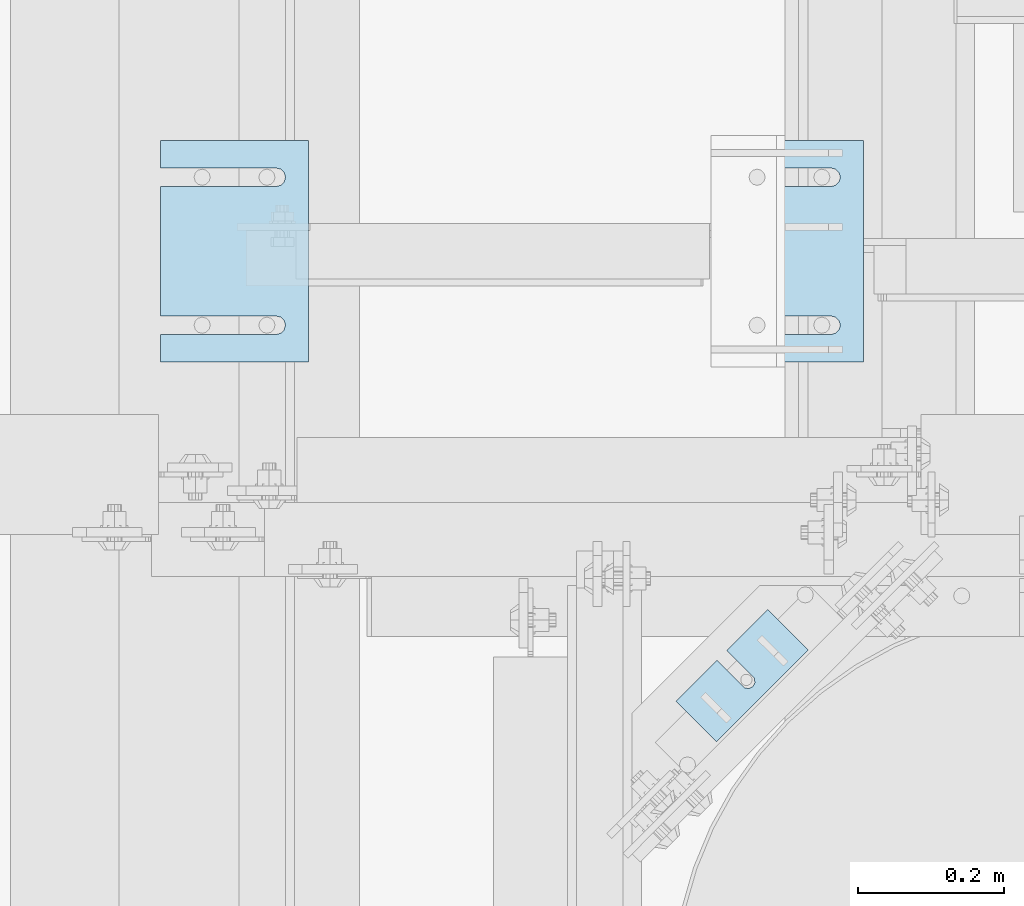
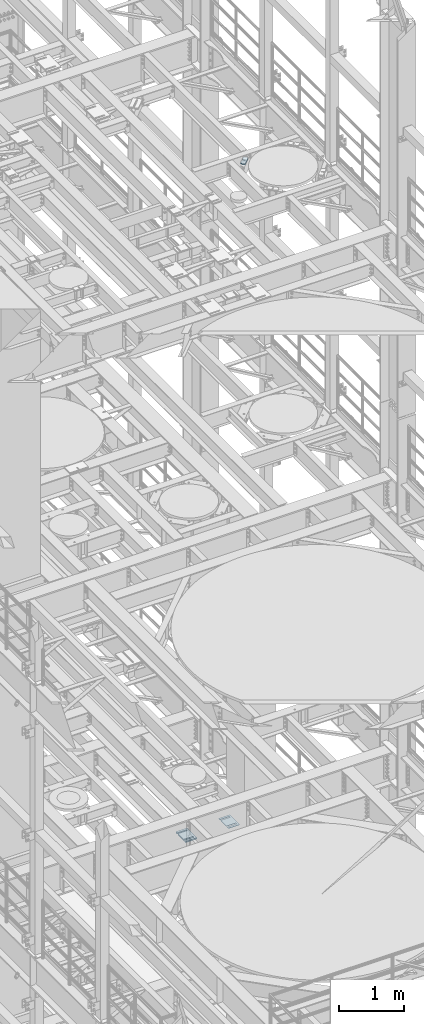
# One storey, part 1658 of 1876: 8 plates, 8 elements without a shape of their own.
"""IFC2X3 building model written with IfcOpenShell, lengths in millimetres."""

from ifc_helpers import new_model, si_unit, frame, origin_with_axes, place, context, subcontext, project, spatial, faceted_brep, material, type_object, element, aggregate, save


model = new_model("IFC2X3")

# Units and contexts
model_context = context("Model", 3, precision=1e-05, world=origin_with_axes())
body_context = subcontext(model_context, "Body", "Model", "MODEL_VIEW")
ifc_project = project(units=[si_unit("LENGTHUNIT", "METRE", prefix="MILLI"), si_unit("AREAUNIT", "SQUARE_METRE"), si_unit("VOLUMEUNIT", "CUBIC_METRE"), si_unit("MASSUNIT", "GRAM", prefix="KILO"), si_unit("TIMEUNIT", "SECOND"), si_unit("PLANEANGLEUNIT", "RADIAN"), si_unit("SOLIDANGLEUNIT", "STERADIAN"), si_unit("THERMODYNAMICTEMPERATUREUNIT", "DEGREE_CELSIUS"), si_unit("LUMINOUSINTENSITYUNIT", "LUMEN")], contexts=[model_context])

# Site, building, storey
site_placement = place(None, origin_with_axes())
site = spatial("IfcSite", under=ifc_project, at=site_placement, CompositionType="ELEMENT")
building_placement = place(site_placement, origin_with_axes())
building = spatial("IfcBuilding", under=site, at=building_placement, Name="Undefined", CompositionType="ELEMENT")
storey_placement = place(building_placement, origin_with_axes())
storey = spatial("IfcBuildingStorey", under=building, at=storey_placement, Name="Undefined", CompositionType="ELEMENT", Elevation=0.0)

# Assembly, plate
assembly_1_placement = place(storey_placement, origin_with_axes())
assembly_1 = element("IfcElementAssembly", 1, at=assembly_1_placement, inside=storey, Name="SHIM PLATE", AssemblyPlace="NOTDEFINED", PredefinedType="RIGID_FRAME")
ifc_material = material(Name="STEEL/A36")
plate_type_1 = type_object("IfcPlateType", PredefinedType="NOTDEFINED")
plate_1_placement = place(assembly_1_placement, frame((6334.01600597448, 4165.55524499807, 17987.9625), z_axis=(0.707106066686187, -0.707107495686186, 0.0), x_axis=(0.707107495686187, 0.707106066686186, 0.0)))
plate_1 = element("IfcPlate", 2, at=plate_1_placement, type_object=plate_type_1, material=ifc_material, Name="SHIM PLATE", context=body_context, shape_type="Brep", body=[
    faceted_brep([(79.3755953647978, -4.76250000000073, -2.27373675443232e-12), (79.3755953647978, 4.76250000000073, -2.27373675443232e-12), (79.3049756952787, 4.76250000000073, 47.6675290359171), (79.3049756952787, -4.76250000000073, 47.6675290359171), (79.4487723981238, 4.76250000000073, 53.7022829617517), (79.4487723981238, -4.76250000000073, 53.7022829617517), (83.0634981204839, 4.76250000000073, 58.5368140030459), (83.0634981204839, -4.76250000000073, 58.5368140030459), (88.8111609071975, 4.76250000000073, 60.3816188510955), (88.8111609071975, -4.76250000000073, 60.3816188510955), (94.5642614235203, 4.76250000000073, 58.5538423641483), (94.5642614235203, -4.76250000000073, 58.5538423641483), (98.354954051083, -4.76250000000073, 47.6957349820682), (98.354954051083, 4.76250000000073, 47.6957349820682), (98.4255737206076, 4.76250000000073, -2.27373675443232e-12), (98.4255737206076, -4.76250000000073, -2.27373675443232e-12), (98.1932875572456, -4.76250000000073, 53.7300366303025), (98.1932875572456, 4.76250000000073, 53.7300366303025), (0.0, -4.76249999999982, 0.0), (7.93202807471971e-05, -4.76250000000073, 78.4900512695085), (7.93202807471971e-05, 4.76250000000073, 78.4900512695085), (0.0, 4.76249999999982, 0.0), (177.801101684615, -4.76250000000073, 78.4900512695531), (177.801101684615, 4.76250000000073, 78.4900512695531), (177.801147461001, -4.76250000000073, -5.00222085975111e-12), (177.801147461001, 4.76250000000073, -5.00222085975111e-12)], [[[0, 1, 2, 3]], [[3, 2, 4, 5]], [[5, 4, 6, 7]], [[7, 6, 8, 9]], [[9, 8, 10, 11]], [[12, 13, 14, 15]], [[16, 17, 13, 12]], [[11, 10, 17, 16]], [[18, 19, 20, 21]], [[19, 22, 23, 20]], [[22, 24, 25, 23]], [[25, 24, 15, 14]], [[8, 6, 4, 2, 1, 21, 20, 23, 25, 14, 13, 17, 10]], [[18, 21, 1, 0]], [[15, 24, 22, 19, 18, 0, 3, 5, 7, 9, 11, 16, 12]]]),
])
aggregate(assembly_1, [plate_1])

assembly_2_placement = place(storey_placement, origin_with_axes())
assembly_2 = element("IfcElementAssembly", 3, at=assembly_2_placement, inside=storey, Name="SHIM PLATE", AssemblyPlace="NOTDEFINED", PredefinedType="RIGID_FRAME")
plate_type_2 = type_object("IfcPlateType", PredefinedType="NOTDEFINED")
plate_2_placement = place(assembly_2_placement, frame((5829.30163886406, 4935.78240966797, 5156.9925), z_axis=(0.0, -1.0, 0.0), x_axis=(-1.0, 0.0, 0.0)))
plate_2 = element("IfcPlate", 4, at=plate_2_placement, type_object=plate_type_2, material=ifc_material, Name="SHIM PLATE", context=body_context, shape_type="Brep", body=[
    faceted_brep([(203.203060149864, -0.793499999999767, 38.103375484061), (203.203060149864, 0.793499999999767, 38.103375484061), (44.4515180349072, 0.793499999999767, 38.1033599194234), (44.4515180349072, -0.793499999999767, 38.1033599194234), (38.1012989900946, 0.793499999999767, 39.8049650059329), (38.1012989900946, -0.793499999999767, 39.8049650059329), (33.4527432566938, 0.793499999999767, 44.4538004924834), (33.4527432566938, -0.793499999999767, 44.4538004924834), (31.7515203221337, 0.793499999999767, 50.8041219264314), (31.7515203221337, -0.793499999999767, 50.8041219264314), (33.4535054350818, 0.793499999999767, 57.1542391271487), (33.4535054350818, -0.793499999999767, 57.1542391271487), (38.1026191065821, 0.793499999999767, 61.8025166422076), (38.1026191065821, -0.793499999999767, 61.8025166422076), (44.4530423390133, 0.793499999999767, 63.5033595381083), (44.4530423390133, -0.793499999999767, 63.5033595381083), (203.203057597802, -0.793499999999767, 63.5033693805453), (203.203057606771, 0.793499999999767, 63.5033693805453), (203.203063964842, -0.793499999999767, -8.45830072648823e-11), (9.09494701772928e-13, -0.793499999999767, 0.0), (9.09494701772928e-13, 0.793499999999767, 0.0), (203.203063964842, 0.793499999999767, -8.45830072648823e-11), (-1.83106603799388e-05, -0.793499999999767, 304.8037109375), (-1.83106603799388e-05, 0.793499999999767, 304.8037109375), (203.203033447349, -0.793499999999767, 304.803710937444), (203.203033447349, 0.793499999999767, 304.803710937444), (203.20303725321, -0.793499999999767, 266.701819087575), (203.203037262178, 0.793499999999767, 266.701819087575), (44.4530372532099, -0.793499999999767, 266.701809245139), (44.4530372532099, 0.793499999999767, 266.701809245139), (38.1026140207787, -0.793499999999767, 265.000966349239), (38.1026140207787, 0.793499999999767, 265.000966349239), (33.4535003492774, -0.793499999999767, 260.352688834179), (33.4535003492774, 0.793499999999767, 260.352688834179), (31.7515152363312, -0.793499999999767, 254.002571633462), (31.7515152363312, 0.793499999999767, 254.002571633462), (33.4527381708904, -0.793499999999767, 247.652250199514), (33.4527381708904, 0.793499999999767, 247.652250199514), (38.1012939042912, -0.793499999999767, 243.003414712964), (38.1012939042912, 0.793499999999767, 243.003414712964), (44.4515129491037, -0.793499999999767, 241.301809626454), (44.4515129491037, 0.793499999999767, 241.301809626454), (203.203039805271, -0.793499999999767, 241.301825191091), (203.203039805271, 0.793499999999767, 241.301825191091)], [[[0, 1, 2, 3]], [[3, 2, 4, 5]], [[5, 4, 6, 7]], [[7, 6, 8, 9]], [[9, 8, 10, 11]], [[11, 10, 12, 13]], [[13, 12, 14, 15]], [[16, 15, 14, 17]], [[18, 19, 20, 21]], [[19, 22, 23, 20]], [[22, 24, 25, 23]], [[25, 24, 26, 27]], [[26, 28, 29, 27]], [[30, 31, 29, 28]], [[32, 33, 31, 30]], [[34, 35, 33, 32]], [[36, 37, 35, 34]], [[38, 39, 37, 36]], [[40, 41, 39, 38]], [[42, 43, 41, 40]], [[43, 42, 16, 17]], [[12, 10, 8, 6, 4, 2, 1, 21, 20, 23, 25, 27, 29, 31, 33, 35, 37, 39, 41, 43, 17, 14]], [[18, 21, 1, 0]], [[42, 40, 38, 36, 34, 32, 30, 28, 26, 24, 22, 19, 18, 0, 3, 5, 7, 9, 11, 13, 15, 16]]]),
])
aggregate(assembly_2, [plate_2])

assembly_3_placement = place(storey_placement, origin_with_axes())
assembly_3 = element("IfcElementAssembly", 5, at=assembly_3_placement, inside=storey, Name="SHIM PLATE", AssemblyPlace="NOTDEFINED", PredefinedType="RIGID_FRAME")
plate_type_3 = type_object("IfcPlateType", PredefinedType="NOTDEFINED")
plate_3_placement = place(assembly_3_placement, frame((5829.30163886406, 4935.78240966797, 5154.6115), z_axis=(0.0, -1.0, 0.0), x_axis=(-1.0, 0.0, 0.0)))
plate_3 = element("IfcPlate", 6, at=plate_3_placement, type_object=plate_type_3, material=ifc_material, Name="SHIM PLATE", context=body_context, shape_type="Brep", body=[
    faceted_brep([(203.203060149865, -1.58749999999964, 38.1033754840619), (203.203060149865, 1.58749999999964, 38.1033754840619), (44.4515180349081, 1.58749999999964, 38.1033599194243), (44.4515180349081, -1.58749999999964, 38.1033599194243), (38.1012989900955, 1.58749999999964, 39.8049650059338), (38.1012989900955, -1.58749999999964, 39.8049650059338), (33.4527432566947, 1.58749999999964, 44.4538004924843), (33.4527432566947, -1.58749999999964, 44.4538004924843), (31.7515203221346, 1.58749999999964, 50.8041219264323), (31.7515203221346, -1.58749999999964, 50.8041219264323), (33.4535054350827, 1.58749999999964, 57.1542391271496), (33.4535054350827, -1.58749999999964, 57.1542391271496), (38.102619106583, 1.58749999999964, 61.8025166422085), (38.102619106583, -1.58749999999964, 61.8025166422085), (44.4530423390142, 1.58749999999964, 63.5033595381092), (44.4530423390142, -1.58749999999964, 63.5033595381092), (203.203057597803, -1.58749999999964, 63.5033693805462), (203.203057606772, 1.58749999999964, 63.5033693805462), (203.203063964843, -1.58749999999964, -8.36735125631094e-11), (9.09494701772928e-13, -1.58750000000146, 4.54747350886464e-13), (9.09494701772928e-13, 1.58750000000146, 4.54747350886464e-13), (203.203063964843, 1.58749999999964, -8.36735125631094e-11), (-1.83106631084229e-05, -1.58749999999964, 304.803710937501), (-1.83106631084229e-05, 1.58749999999964, 304.803710937501), (203.20303344735, -1.58749999999964, 304.803710937445), (203.20303344735, 1.58749999999964, 304.803710937445), (203.203037253211, -1.58749999999964, 266.701819087576), (203.203037262179, 1.58749999999964, 266.701819087576), (44.4530372532108, -1.58749999999964, 266.70180924514), (44.4530372532108, 1.58749999999964, 266.70180924514), (38.1026140207796, -1.58749999999964, 265.00096634924), (38.1026140207796, 1.58749999999964, 265.00096634924), (33.4535003492783, -1.58749999999964, 260.35268883418), (33.4535003492783, 1.58749999999964, 260.35268883418), (31.7515152363321, -1.58749999999964, 254.002571633463), (31.7515152363321, 1.58749999999964, 254.002571633463), (33.4527381708913, -1.58749999999964, 247.652250199515), (33.4527381708913, 1.58749999999964, 247.652250199515), (38.1012939042921, -1.58749999999964, 243.003414712965), (38.1012939042921, 1.58749999999964, 243.003414712965), (44.4515129491047, -1.58749999999964, 241.301809626455), (44.4515129491047, 1.58749999999964, 241.301809626455), (203.203039805272, -1.58749999999964, 241.301825191092), (203.203039805272, 1.58749999999964, 241.301825191092)], [[[0, 1, 2, 3]], [[3, 2, 4, 5]], [[5, 4, 6, 7]], [[7, 6, 8, 9]], [[9, 8, 10, 11]], [[11, 10, 12, 13]], [[13, 12, 14, 15]], [[16, 15, 14, 17]], [[18, 19, 20, 21]], [[19, 22, 23, 20]], [[22, 24, 25, 23]], [[25, 24, 26, 27]], [[26, 28, 29, 27]], [[30, 31, 29, 28]], [[32, 33, 31, 30]], [[34, 35, 33, 32]], [[36, 37, 35, 34]], [[38, 39, 37, 36]], [[40, 41, 39, 38]], [[42, 43, 41, 40]], [[43, 42, 16, 17]], [[12, 10, 8, 6, 4, 2, 1, 21, 20, 23, 25, 27, 29, 31, 33, 35, 37, 39, 41, 43, 17, 14]], [[18, 21, 1, 0]], [[42, 40, 38, 36, 34, 32, 30, 28, 26, 24, 22, 19, 18, 0, 3, 5, 7, 9, 11, 13, 15, 16]]]),
])
aggregate(assembly_3, [plate_3])

assembly_4_placement = place(storey_placement, origin_with_axes())
assembly_4 = element("IfcElementAssembly", 7, at=assembly_4_placement, inside=storey, Name="SHIM PLATE", AssemblyPlace="NOTDEFINED", PredefinedType="RIGID_FRAME")
plate_4_placement = place(assembly_4_placement, frame((5829.30163886406, 4935.78240966797, 5151.4365), z_axis=(0.0, -1.0, 0.0), x_axis=(-1.0, 0.0, 0.0)))
plate_4 = element("IfcPlate", 8, at=plate_4_placement, type_object=plate_type_3, material=ifc_material, Name="SHIM PLATE", context=body_context, shape_type="Brep", body=[
    faceted_brep([(203.203060149865, -1.58749999999964, 38.1033754840619), (203.203060149865, 1.58749999999964, 38.1033754840619), (44.4515180349081, 1.58749999999964, 38.1033599194243), (44.4515180349081, -1.58749999999964, 38.1033599194243), (38.1012989900955, 1.58749999999964, 39.8049650059338), (38.1012989900955, -1.58749999999964, 39.8049650059338), (33.4527432566947, 1.58749999999964, 44.4538004924843), (33.4527432566947, -1.58749999999964, 44.4538004924843), (31.7515203221346, 1.58749999999964, 50.8041219264323), (31.7515203221346, -1.58749999999964, 50.8041219264323), (33.4535054350827, 1.58749999999964, 57.1542391271496), (33.4535054350827, -1.58749999999964, 57.1542391271496), (38.102619106583, 1.58749999999964, 61.8025166422085), (38.102619106583, -1.58749999999964, 61.8025166422085), (44.4530423390142, 1.58749999999964, 63.5033595381092), (44.4530423390142, -1.58749999999964, 63.5033595381092), (203.203057597803, -1.58749999999964, 63.5033693805462), (203.203057606772, 1.58749999999964, 63.5033693805462), (203.203063964843, -1.58749999999964, -8.36735125631094e-11), (9.09494701772928e-13, -1.58750000000146, 4.54747350886464e-13), (9.09494701772928e-13, 1.58750000000146, 4.54747350886464e-13), (203.203063964843, 1.58749999999964, -8.36735125631094e-11), (-1.83106631084229e-05, -1.58749999999964, 304.803710937501), (-1.83106631084229e-05, 1.58749999999964, 304.803710937501), (203.20303344735, -1.58749999999964, 304.803710937445), (203.20303344735, 1.58749999999964, 304.803710937445), (203.203037253211, -1.58749999999964, 266.701819087576), (203.203037262179, 1.58749999999964, 266.701819087576), (44.4530372532108, -1.58749999999964, 266.70180924514), (44.4530372532108, 1.58749999999964, 266.70180924514), (38.1026140207796, -1.58749999999964, 265.00096634924), (38.1026140207796, 1.58749999999964, 265.00096634924), (33.4535003492783, -1.58749999999964, 260.35268883418), (33.4535003492783, 1.58749999999964, 260.35268883418), (31.7515152363321, -1.58749999999964, 254.002571633463), (31.7515152363321, 1.58749999999964, 254.002571633463), (33.4527381708913, -1.58749999999964, 247.652250199515), (33.4527381708913, 1.58749999999964, 247.652250199515), (38.1012939042921, -1.58749999999964, 243.003414712965), (38.1012939042921, 1.58749999999964, 243.003414712965), (44.4515129491047, -1.58749999999964, 241.301809626455), (44.4515129491047, 1.58749999999964, 241.301809626455), (203.203039805272, -1.58749999999964, 241.301825191092), (203.203039805272, 1.58749999999964, 241.301825191092)], [[[0, 1, 2, 3]], [[3, 2, 4, 5]], [[5, 4, 6, 7]], [[7, 6, 8, 9]], [[9, 8, 10, 11]], [[11, 10, 12, 13]], [[13, 12, 14, 15]], [[16, 15, 14, 17]], [[18, 19, 20, 21]], [[19, 22, 23, 20]], [[22, 24, 25, 23]], [[25, 24, 26, 27]], [[26, 28, 29, 27]], [[30, 31, 29, 28]], [[32, 33, 31, 30]], [[34, 35, 33, 32]], [[36, 37, 35, 34]], [[38, 39, 37, 36]], [[40, 41, 39, 38]], [[42, 43, 41, 40]], [[43, 42, 16, 17]], [[12, 10, 8, 6, 4, 2, 1, 21, 20, 23, 25, 27, 29, 31, 33, 35, 37, 39, 41, 43, 17, 14]], [[18, 21, 1, 0]], [[42, 40, 38, 36, 34, 32, 30, 28, 26, 24, 22, 19, 18, 0, 3, 5, 7, 9, 11, 13, 15, 16]]]),
])
aggregate(assembly_4, [plate_4])

assembly_5_placement = place(storey_placement, origin_with_axes())
assembly_5 = element("IfcElementAssembly", 9, at=assembly_5_placement, inside=storey, Name="SHIM PLATE", AssemblyPlace="NOTDEFINED", PredefinedType="RIGID_FRAME")
plate_type_4 = type_object("IfcPlateType", PredefinedType="NOTDEFINED")
plate_5_placement = place(assembly_5_placement, frame((5829.30163886406, 4935.78240966797, 5147.468), z_axis=(0.0, -1.0, 0.0), x_axis=(-1.0, 0.0, 0.0)))
plate_5 = element("IfcPlate", 10, at=plate_5_placement, type_object=plate_type_4, material=ifc_material, Name="SHIM PLATE", context=body_context, shape_type="Brep", body=[
    faceted_brep([(203.203060149865, -2.38100000000031, 38.1033754840619), (203.203060149865, 2.38100000000031, 38.1033754840619), (44.4515180349081, 2.38100000000031, 38.1033599194243), (44.4515180349081, -2.38100000000031, 38.1033599194243), (38.1012989900955, 2.38100000000031, 39.8049650059338), (38.1012989900955, -2.38100000000031, 39.8049650059338), (33.4527432566947, 2.38100000000031, 44.4538004924843), (33.4527432566947, -2.38100000000031, 44.4538004924843), (31.7515203221346, 2.38100000000031, 50.8041219264323), (31.7515203221346, -2.38100000000031, 50.8041219264323), (33.4535054350827, 2.38100000000031, 57.1542391271496), (33.4535054350827, -2.38100000000031, 57.1542391271496), (38.102619106583, 2.38100000000031, 61.8025166422085), (38.102619106583, -2.38100000000031, 61.8025166422085), (44.4530423390142, 2.38100000000031, 63.5033595381092), (44.4530423390142, -2.38100000000031, 63.5033595381092), (203.203057597803, -2.38100000000031, 63.5033693805462), (203.203057606772, 2.38100000000031, 63.5033693805462), (203.203063964843, -2.38100000000031, -8.36735125631094e-11), (0.0, -2.38100000000122, 4.54747350886464e-13), (0.0, 2.38100000000122, 4.54747350886464e-13), (203.203063964843, 2.38100000000031, -8.36735125631094e-11), (-1.83106667464017e-05, -2.38100000000031, 304.803710937501), (-1.83106667464017e-05, 2.38100000000031, 304.803710937501), (203.20303344735, -2.38100000000031, 304.803710937445), (203.20303344735, 2.38100000000031, 304.803710937445), (203.203037253211, -2.38100000000031, 266.701819087576), (203.203037262179, 2.38100000000031, 266.701819087576), (44.4530372532108, -2.38100000000031, 266.70180924514), (44.4530372532108, 2.38100000000031, 266.70180924514), (38.1026140207796, -2.38100000000031, 265.00096634924), (38.1026140207796, 2.38100000000031, 265.00096634924), (33.4535003492783, -2.38100000000031, 260.35268883418), (33.4535003492783, 2.38100000000031, 260.35268883418), (31.7515152363321, -2.38100000000031, 254.002571633463), (31.7515152363321, 2.38100000000031, 254.002571633463), (33.4527381708913, -2.38100000000031, 247.652250199515), (33.4527381708913, 2.38100000000031, 247.652250199515), (38.1012939042921, -2.38100000000031, 243.003414712965), (38.1012939042921, 2.38100000000031, 243.003414712965), (44.4515129491047, -2.38100000000031, 241.301809626455), (44.4515129491047, 2.38100000000031, 241.301809626455), (203.203039805272, -2.38100000000031, 241.301825191092), (203.203039805272, 2.38100000000031, 241.301825191092)], [[[0, 1, 2, 3]], [[3, 2, 4, 5]], [[5, 4, 6, 7]], [[7, 6, 8, 9]], [[9, 8, 10, 11]], [[11, 10, 12, 13]], [[13, 12, 14, 15]], [[16, 15, 14, 17]], [[18, 19, 20, 21]], [[19, 22, 23, 20]], [[22, 24, 25, 23]], [[25, 24, 26, 27]], [[26, 28, 29, 27]], [[30, 31, 29, 28]], [[32, 33, 31, 30]], [[34, 35, 33, 32]], [[36, 37, 35, 34]], [[38, 39, 37, 36]], [[40, 41, 39, 38]], [[42, 43, 41, 40]], [[43, 42, 16, 17]], [[12, 10, 8, 6, 4, 2, 1, 21, 20, 23, 25, 27, 29, 31, 33, 35, 37, 39, 41, 43, 17, 14]], [[18, 21, 1, 0]], [[42, 40, 38, 36, 34, 32, 30, 28, 26, 24, 22, 19, 18, 0, 3, 5, 7, 9, 11, 13, 15, 16]]]),
])
aggregate(assembly_5, [plate_5])

assembly_6_placement = place(storey_placement, origin_with_axes())
assembly_6 = element("IfcElementAssembly", 11, at=assembly_6_placement, inside=storey, Name="SHIM PLATE", AssemblyPlace="NOTDEFINED", PredefinedType="RIGID_FRAME")
plate_6_placement = place(assembly_6_placement, frame((5829.30163886406, 4935.78240966797, 5142.706), z_axis=(0.0, -1.0, 0.0), x_axis=(-1.0, 0.0, 0.0)))
plate_6 = element("IfcPlate", 12, at=plate_6_placement, type_object=plate_type_4, material=ifc_material, Name="SHIM PLATE", context=body_context, shape_type="Brep", body=[
    faceted_brep([(203.203060149865, -2.38100000000031, 38.1033754840619), (203.203060149865, 2.38100000000031, 38.1033754840619), (44.4515180349081, 2.38100000000031, 38.1033599194243), (44.4515180349081, -2.38100000000031, 38.1033599194243), (38.1012989900955, 2.38100000000031, 39.8049650059338), (38.1012989900955, -2.38100000000031, 39.8049650059338), (33.4527432566947, 2.38100000000031, 44.4538004924843), (33.4527432566947, -2.38100000000031, 44.4538004924843), (31.7515203221346, 2.38100000000031, 50.8041219264323), (31.7515203221346, -2.38100000000031, 50.8041219264323), (33.4535054350827, 2.38100000000031, 57.1542391271496), (33.4535054350827, -2.38100000000031, 57.1542391271496), (38.102619106583, 2.38100000000031, 61.8025166422085), (38.102619106583, -2.38100000000031, 61.8025166422085), (44.4530423390142, 2.38100000000031, 63.5033595381092), (44.4530423390142, -2.38100000000031, 63.5033595381092), (203.203057597803, -2.38100000000031, 63.5033693805462), (203.203057606772, 2.38100000000031, 63.5033693805462), (203.203063964843, -2.38100000000031, -8.36735125631094e-11), (0.0, -2.38100000000122, 4.54747350886464e-13), (0.0, 2.38100000000122, 4.54747350886464e-13), (203.203063964843, 2.38100000000031, -8.36735125631094e-11), (-1.83106667464017e-05, -2.38100000000031, 304.803710937501), (-1.83106667464017e-05, 2.38100000000031, 304.803710937501), (203.20303344735, -2.38100000000031, 304.803710937445), (203.20303344735, 2.38100000000031, 304.803710937445), (203.203037253211, -2.38100000000031, 266.701819087576), (203.203037262179, 2.38100000000031, 266.701819087576), (44.4530372532108, -2.38100000000031, 266.70180924514), (44.4530372532108, 2.38100000000031, 266.70180924514), (38.1026140207796, -2.38100000000031, 265.00096634924), (38.1026140207796, 2.38100000000031, 265.00096634924), (33.4535003492783, -2.38100000000031, 260.35268883418), (33.4535003492783, 2.38100000000031, 260.35268883418), (31.7515152363321, -2.38100000000031, 254.002571633463), (31.7515152363321, 2.38100000000031, 254.002571633463), (33.4527381708913, -2.38100000000031, 247.652250199515), (33.4527381708913, 2.38100000000031, 247.652250199515), (38.1012939042921, -2.38100000000031, 243.003414712965), (38.1012939042921, 2.38100000000031, 243.003414712965), (44.4515129491047, -2.38100000000031, 241.301809626455), (44.4515129491047, 2.38100000000031, 241.301809626455), (203.203039805272, -2.38100000000031, 241.301825191092), (203.203039805272, 2.38100000000031, 241.301825191092)], [[[0, 1, 2, 3]], [[3, 2, 4, 5]], [[5, 4, 6, 7]], [[7, 6, 8, 9]], [[9, 8, 10, 11]], [[11, 10, 12, 13]], [[13, 12, 14, 15]], [[16, 15, 14, 17]], [[18, 19, 20, 21]], [[19, 22, 23, 20]], [[22, 24, 25, 23]], [[25, 24, 26, 27]], [[26, 28, 29, 27]], [[30, 31, 29, 28]], [[32, 33, 31, 30]], [[34, 35, 33, 32]], [[36, 37, 35, 34]], [[38, 39, 37, 36]], [[40, 41, 39, 38]], [[42, 43, 41, 40]], [[43, 42, 16, 17]], [[12, 10, 8, 6, 4, 2, 1, 21, 20, 23, 25, 27, 29, 31, 33, 35, 37, 39, 41, 43, 17, 14]], [[18, 21, 1, 0]], [[42, 40, 38, 36, 34, 32, 30, 28, 26, 24, 22, 19, 18, 0, 3, 5, 7, 9, 11, 13, 15, 16]]]),
])
aggregate(assembly_6, [plate_6])

assembly_7_placement = place(storey_placement, origin_with_axes())
assembly_7 = element("IfcElementAssembly", 13, at=assembly_7_placement, inside=storey, Name="SHIM PLATE", AssemblyPlace="NOTDEFINED", PredefinedType="RIGID_FRAME")
plate_type_5 = type_object("IfcPlateType", PredefinedType="NOTDEFINED")
plate_7_placement = place(assembly_7_placement, frame((6591.29886176445, 4935.78240966797, 5135.5625), z_axis=(0.0, -1.0, 0.0), x_axis=(-1.0, 0.0, 0.0)))
plate_7 = element("IfcPlate", 14, at=plate_7_placement, type_object=plate_type_5, material=ifc_material, Name="SHIM PLATE", context=body_context, shape_type="Brep", body=[
    faceted_brep([(203.203060149865, -4.76249999999982, 38.1033754840619), (203.203060149865, 4.76249999999982, 38.1033754840619), (44.4515180349081, 4.76249999999982, 38.1033599194243), (44.4515180349081, -4.76249999999982, 38.1033599194243), (38.1012989900955, 4.76249999999982, 39.8049650059338), (38.1012989900955, -4.76249999999982, 39.8049650059338), (33.4527432566947, 4.76249999999982, 44.4538004924843), (33.4527432566947, -4.76249999999982, 44.4538004924843), (31.7515203221346, 4.76249999999982, 50.8041219264323), (31.7515203221346, -4.76249999999982, 50.8041219264323), (33.4535054350827, 4.76249999999982, 57.1542391271496), (33.4535054350827, -4.76249999999982, 57.1542391271496), (38.102619106583, 4.76249999999982, 61.8025166422085), (38.102619106583, -4.76249999999982, 61.8025166422085), (44.4530423390142, 4.76249999999982, 63.5033595381092), (44.4530423390142, -4.76249999999982, 63.5033595381092), (203.203057597803, -4.76249999999982, 63.5033693805462), (203.203057606772, 4.76249999999982, 63.5033693805462), (203.203063964843, -4.76249999999982, -8.36735125631094e-11), (0.0, -4.76249999999982, 0.0), (0.0, 4.76249999999982, 0.0), (203.203063964843, 4.76249999999982, -8.36735125631094e-11), (-1.83106703843805e-05, -4.76249999999982, 304.803710937501), (-1.83106703843805e-05, 4.76249999999982, 304.803710937501), (203.20303344735, -4.76249999999982, 304.803710937445), (203.20303344735, 4.76249999999982, 304.803710937445), (203.203037253211, -4.76249999999982, 266.701819087576), (203.203037262179, 4.76249999999982, 266.701819087576), (44.4530372532108, -4.76249999999982, 266.70180924514), (44.4530372532108, 4.76249999999982, 266.70180924514), (38.1026140207796, -4.76249999999982, 265.00096634924), (38.1026140207796, 4.76249999999982, 265.00096634924), (33.4535003492783, -4.76249999999982, 260.35268883418), (33.4535003492783, 4.76249999999982, 260.35268883418), (31.7515152363321, -4.76249999999982, 254.002571633463), (31.7515152363321, 4.76249999999982, 254.002571633463), (33.4527381708913, -4.76249999999982, 247.652250199515), (33.4527381708913, 4.76249999999982, 247.652250199515), (38.1012939042921, -4.76249999999982, 243.003414712965), (38.1012939042921, 4.76249999999982, 243.003414712965), (44.4515129491047, -4.76249999999982, 241.301809626455), (44.4515129491047, 4.76249999999982, 241.301809626455), (203.203039805272, -4.76249999999982, 241.301825191092), (203.203039805272, 4.76249999999982, 241.301825191092)], [[[0, 1, 2, 3]], [[3, 2, 4, 5]], [[5, 4, 6, 7]], [[7, 6, 8, 9]], [[9, 8, 10, 11]], [[11, 10, 12, 13]], [[13, 12, 14, 15]], [[16, 15, 14, 17]], [[18, 19, 20, 21]], [[19, 22, 23, 20]], [[22, 24, 25, 23]], [[25, 24, 26, 27]], [[26, 28, 29, 27]], [[30, 31, 29, 28]], [[32, 33, 31, 30]], [[34, 35, 33, 32]], [[36, 37, 35, 34]], [[38, 39, 37, 36]], [[40, 41, 39, 38]], [[42, 43, 41, 40]], [[43, 42, 16, 17]], [[12, 10, 8, 6, 4, 2, 1, 21, 20, 23, 25, 27, 29, 31, 33, 35, 37, 39, 41, 43, 17, 14]], [[18, 21, 1, 0]], [[42, 40, 38, 36, 34, 32, 30, 28, 26, 24, 22, 19, 18, 0, 3, 5, 7, 9, 11, 13, 15, 16]]]),
])
aggregate(assembly_7, [plate_7])

assembly_8_placement = place(storey_placement, origin_with_axes())
assembly_8 = element("IfcElementAssembly", 15, at=assembly_8_placement, inside=storey, Name="SHIM PLATE", AssemblyPlace="NOTDEFINED", PredefinedType="RIGID_FRAME")
plate_8_placement = place(assembly_8_placement, frame((5829.30163886406, 4935.78240966797, 5135.5625), z_axis=(0.0, -1.0, 0.0), x_axis=(-1.0, 0.0, 0.0)))
plate_8 = element("IfcPlate", 16, at=plate_8_placement, type_object=plate_type_5, material=ifc_material, Name="SHIM PLATE", context=body_context, shape_type="Brep", body=[
    faceted_brep([(203.203060149865, -4.76249999999982, 38.1033754840619), (203.203060149865, 4.76249999999982, 38.1033754840619), (44.4515180349081, 4.76249999999982, 38.1033599194243), (44.4515180349081, -4.76249999999982, 38.1033599194243), (38.1012989900955, 4.76249999999982, 39.8049650059338), (38.1012989900955, -4.76249999999982, 39.8049650059338), (33.4527432566947, 4.76249999999982, 44.4538004924843), (33.4527432566947, -4.76249999999982, 44.4538004924843), (31.7515203221346, 4.76249999999982, 50.8041219264323), (31.7515203221346, -4.76249999999982, 50.8041219264323), (33.4535054350827, 4.76249999999982, 57.1542391271496), (33.4535054350827, -4.76249999999982, 57.1542391271496), (38.102619106583, 4.76249999999982, 61.8025166422085), (38.102619106583, -4.76249999999982, 61.8025166422085), (44.4530423390142, 4.76249999999982, 63.5033595381092), (44.4530423390142, -4.76249999999982, 63.5033595381092), (203.203057597803, -4.76249999999982, 63.5033693805462), (203.203057606772, 4.76249999999982, 63.5033693805462), (203.203063964843, -4.76249999999982, -8.36735125631094e-11), (0.0, -4.76249999999982, 0.0), (0.0, 4.76249999999982, 0.0), (203.203063964843, 4.76249999999982, -8.36735125631094e-11), (-1.83106703843805e-05, -4.76249999999982, 304.803710937501), (-1.83106703843805e-05, 4.76249999999982, 304.803710937501), (203.20303344735, -4.76249999999982, 304.803710937445), (203.20303344735, 4.76249999999982, 304.803710937445), (203.203037253211, -4.76249999999982, 266.701819087576), (203.203037262179, 4.76249999999982, 266.701819087576), (44.4530372532108, -4.76249999999982, 266.70180924514), (44.4530372532108, 4.76249999999982, 266.70180924514), (38.1026140207796, -4.76249999999982, 265.00096634924), (38.1026140207796, 4.76249999999982, 265.00096634924), (33.4535003492783, -4.76249999999982, 260.35268883418), (33.4535003492783, 4.76249999999982, 260.35268883418), (31.7515152363321, -4.76249999999982, 254.002571633463), (31.7515152363321, 4.76249999999982, 254.002571633463), (33.4527381708913, -4.76249999999982, 247.652250199515), (33.4527381708913, 4.76249999999982, 247.652250199515), (38.1012939042921, -4.76249999999982, 243.003414712965), (38.1012939042921, 4.76249999999982, 243.003414712965), (44.4515129491047, -4.76249999999982, 241.301809626455), (44.4515129491047, 4.76249999999982, 241.301809626455), (203.203039805272, -4.76249999999982, 241.301825191092), (203.203039805272, 4.76249999999982, 241.301825191092)], [[[0, 1, 2, 3]], [[3, 2, 4, 5]], [[5, 4, 6, 7]], [[7, 6, 8, 9]], [[9, 8, 10, 11]], [[11, 10, 12, 13]], [[13, 12, 14, 15]], [[16, 15, 14, 17]], [[18, 19, 20, 21]], [[19, 22, 23, 20]], [[22, 24, 25, 23]], [[25, 24, 26, 27]], [[26, 28, 29, 27]], [[30, 31, 29, 28]], [[32, 33, 31, 30]], [[34, 35, 33, 32]], [[36, 37, 35, 34]], [[38, 39, 37, 36]], [[40, 41, 39, 38]], [[42, 43, 41, 40]], [[43, 42, 16, 17]], [[12, 10, 8, 6, 4, 2, 1, 21, 20, 23, 25, 27, 29, 31, 33, 35, 37, 39, 41, 43, 17, 14]], [[18, 21, 1, 0]], [[42, 40, 38, 36, 34, 32, 30, 28, 26, 24, 22, 19, 18, 0, 3, 5, 7, 9, 11, 13, 15, 16]]]),
])
aggregate(assembly_8, [plate_8])

save(model, "model.ifc")
